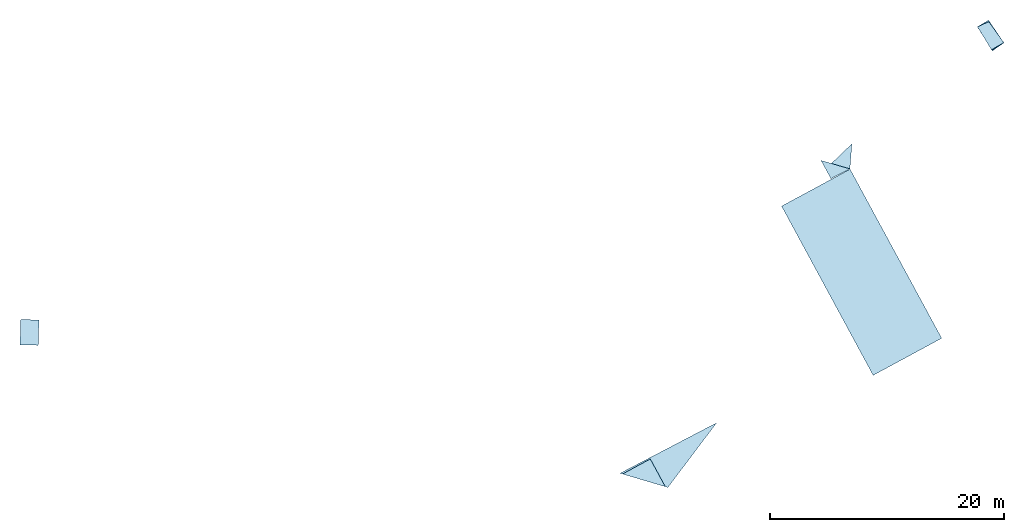
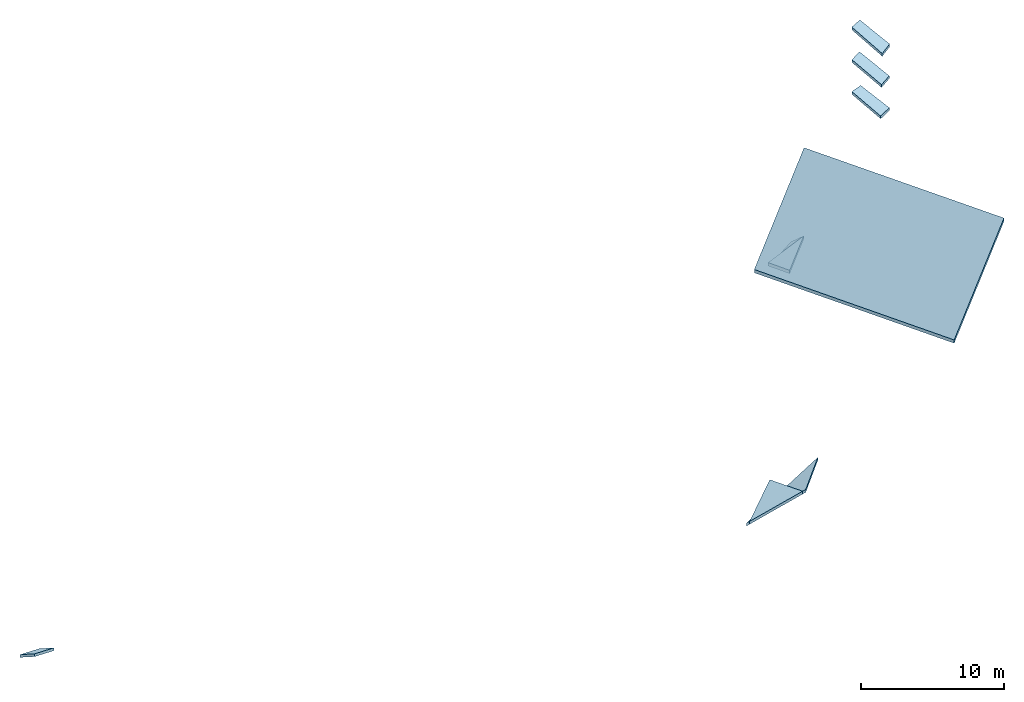
# One storey: 9 slabs, 1 element without a shape of its own.
"""IFC2X3 building model written with IfcOpenShell, lengths in metres."""

from ifc_helpers import new_model, entity, si_unit, converted_unit, derived_unit, direction, frame, origin, place, context, subcontext, project, spatial, polyline, outline, extrude, material, layer, layer_set, type_object, element, aggregate, save


model = new_model("IFC2X3")

# Units and contexts
model_context = context("Model", 3, precision=1e-05, world=origin(), true_north=direction((0.0, 1.0)))
body_context = subcontext(model_context, "Body", "Model", "MODEL_VIEW")
ifc_project = project(units=[si_unit("LENGTHUNIT", "METRE"), si_unit("AREAUNIT", "SQUARE_METRE"), si_unit("VOLUMEUNIT", "CUBIC_METRE"), converted_unit("PLANEANGLEUNIT", "DEGREE", entity("IfcRatioMeasure", 0.0174532925199433), si_unit("PLANEANGLEUNIT", "RADIAN"), dimensions=[0, 0, 0, 0, 0, 0, 0]), si_unit("MASSUNIT", "GRAM", prefix="KILO"), derived_unit("MASSDENSITYUNIT", [(si_unit("MASSUNIT", "GRAM", prefix="KILO"), 1), (si_unit("LENGTHUNIT", "METRE"), -3)]), derived_unit("MOMENTOFINERTIAUNIT", [(si_unit("LENGTHUNIT", "METRE"), 4)]), si_unit("TIMEUNIT", "SECOND"), si_unit("FREQUENCYUNIT", "HERTZ"), si_unit("THERMODYNAMICTEMPERATUREUNIT", "DEGREE_CELSIUS"), derived_unit("THERMALTRANSMITTANCEUNIT", [(si_unit("MASSUNIT", "GRAM", prefix="KILO"), 1), (si_unit("THERMODYNAMICTEMPERATUREUNIT", "KELVIN"), -1), (si_unit("TIMEUNIT", "SECOND"), -3)]), derived_unit("VOLUMETRICFLOWRATEUNIT", [(si_unit("LENGTHUNIT", "METRE"), 3), (si_unit("TIMEUNIT", "SECOND"), -1)]), si_unit("ELECTRICCURRENTUNIT", "AMPERE"), si_unit("ELECTRICVOLTAGEUNIT", "VOLT"), si_unit("POWERUNIT", "WATT"), si_unit("FORCEUNIT", "NEWTON", prefix="KILO"), si_unit("ILLUMINANCEUNIT", "LUX"), si_unit("LUMINOUSFLUXUNIT", "LUMEN"), si_unit("LUMINOUSINTENSITYUNIT", "CANDELA"), derived_unit("USERDEFINED", [(si_unit("MASSUNIT", "GRAM", prefix="KILO"), -1), (si_unit("LENGTHUNIT", "METRE"), -2), (si_unit("TIMEUNIT", "SECOND"), 3), (si_unit("LUMINOUSFLUXUNIT", "LUMEN"), 1)]), derived_unit("LINEARVELOCITYUNIT", [(si_unit("LENGTHUNIT", "METRE"), 1), (si_unit("TIMEUNIT", "SECOND"), -1)]), si_unit("PRESSUREUNIT", "PASCAL"), derived_unit("USERDEFINED", [(si_unit("LENGTHUNIT", "METRE"), -2), (si_unit("MASSUNIT", "GRAM", prefix="KILO"), 1), (si_unit("TIMEUNIT", "SECOND"), -2)]), derived_unit("LINEARFORCEUNIT", [(si_unit("MASSUNIT", "GRAM", prefix="KILO"), 1), (si_unit("LENGTHUNIT", "METRE"), 1), (si_unit("TIMEUNIT", "SECOND"), -2), (si_unit("LENGTHUNIT", "METRE"), -1)]), derived_unit("PLANARFORCEUNIT", [(si_unit("MASSUNIT", "GRAM", prefix="KILO"), 1), (si_unit("LENGTHUNIT", "METRE"), 1), (si_unit("TIMEUNIT", "SECOND"), -2), (si_unit("LENGTHUNIT", "METRE"), -2)])], contexts=[model_context])

# Site, building, storey
placement_1 = place(None, origin())
site = spatial("IfcSite", under=ifc_project, at=placement_1, CompositionType="ELEMENT")
building = spatial("IfcBuilding", under=site, at=placement_1, CompositionType="ELEMENT")
storey_placement = place(placement_1, frame((0.0, 0.0, 31.821325302124)))
storey = spatial("IfcBuildingStorey", under=building, at=storey_placement, Name="Level", CompositionType="ELEMENT", Elevation=31.821325302124)

# Roof, slabs
placement_2 = place(storey_placement, frame((-6.07346868515015, -33.4250411987305, 0.0)))
roof = element("IfcRoof", 1, at=placement_2, inside=storey, Name="Roof", ObjectType="Roof", ShapeType="NOTDEFINED")
ifc_material = material(Name="Roof default")
ifc_layer_1 = layer(ifc_material, 0.231103475607515)
ifc_layer_set_1 = layer_set([ifc_layer_1], Name="Roof : 231mm")
slab_type_1 = type_object("IfcSlabType", Name="Roof : 231mm", PredefinedType="ROOF")
slab_1 = element("IfcSlab", 2, at=placement_2, type_object=slab_type_1, material=ifc_layer_set_1, Name="Roof : 231mm", ObjectType="Roof : 231mm", PredefinedType="ROOF", context=body_context, shape_type="SweptSolid", body=[
    extrude(outline(polyline([(-1.37945548640333, -0.570175826322992), (1.28084587008976, -0.570175826322992), (1.32249920218578, 0.650591080261554), (-1.22388958587222, 0.48976057238443), (-1.37945548640333, -0.570175826322992)])), frame((82.951949596405, 24.317388176918, 3.69791507720947), z_axis=(0.269387876685073, -0.422480949692352, 0.865413207111006), x_axis=(0.45254965347922, -0.737696085330499, -0.501002292234172)), (0.501002292234172, 0.00753277468122775, -0.865413207111006), 0.231103475607515),
])
ifc_layer_2 = layer(ifc_material, 0.246837570702711)
ifc_layer_set_2 = layer_set([ifc_layer_2], Name="Roof : 247mm")
slab_type_2 = type_object("IfcSlabType", Name="Roof : 247mm", PredefinedType="ROOF")
slab_2 = element("IfcSlab", 3, at=placement_2, type_object=slab_type_2, material=ifc_layer_set_2, Name="Roof : 247mm", ObjectType="Roof : 247mm", PredefinedType="ROOF", context=body_context, shape_type="SweptSolid", body=[
    extrude(outline(polyline([(-2.29321118966516, -0.699426958294514), (1.99663056598749, -0.699426958294514), (0.296580623677674, 1.39885391658903), (-2.29321118966516, -0.699426958294514)])), frame((53.4909822146098, -13.15478515625, 2.7156810760498), z_axis=(-0.515052841201762, -0.279672019133781, 0.810249426092748), x_axis=(0.853648696351152, -0.252810824825446, 0.455379610950091)), (-0.455379610950091, -0.368952588152536, -0.810249426092748), 0.246837570702711),
])
ifc_layer_3 = layer(ifc_material, 0.286736122867555)
ifc_layer_set_3 = layer_set([ifc_layer_3], Name="Roof : 287mm")
slab_type_3 = type_object("IfcSlabType", Name="Roof : 287mm", PredefinedType="ROOF")
slab_3 = element("IfcSlab", 4, at=placement_2, type_object=slab_type_3, material=ifc_layer_set_3, Name="Roof : 287mm", ObjectType="Roof : 287mm", PredefinedType="ROOF", context=body_context, shape_type="SweptSolid", body=[
    extrude(outline(polyline([(-1.75380436932726, 0.59299205535376), (0.8696520481115, 0.59299205535376), (0.884152321215753, -1.18598411070752), (-1.75380436932726, 0.59299205535376)])), frame((69.5678445498149, 12.8426265716553, 1.97781562805176), z_axis=(-0.6271914955374, -0.346579018509989, 0.697505420662959), x_axis=(-0.619760830229879, -0.320317024407178, -0.716445055246878)), (0.716445055246878, 0.0138959866679809, -0.697505420662959), 0.286736122867555),
])
ifc_layer_4 = layer(ifc_material, 0.231432763462811)
ifc_layer_set_4 = layer_set([ifc_layer_4], Name="Roof : 231mm")
slab_type_4 = type_object("IfcSlabType", Name="Roof : 231mm", PredefinedType="ROOF")
slab_4 = element("IfcSlab", 5, at=placement_2, type_object=slab_type_4, material=ifc_layer_set_4, Name="Roof : 231mm", ObjectType="Roof : 231mm", PredefinedType="ROOF", context=body_context, shape_type="SweptSolid", body=[
    extrude(outline(polyline([(-1.35076795751455, -0.579947465231267), (1.36930573833615, -0.579947465231267), (1.34047400766751, 0.619872903054224), (-1.35901178848911, 0.540022027408309), (-1.35076795751455, -0.579947465231267)])), frame((82.955897808075, 24.3349380493164, 6.44432258605957), z_axis=(0.270101886591455, -0.424540520788289, 0.864181877308559), x_axis=(0.457661514382487, -0.733055210339754, -0.503165973458926)), (0.503165973458926, 0.00370373762776552, -0.864181877308559), 0.231432763462811),
])
ifc_layer_5 = layer(ifc_material, 0.288298507640401)
ifc_layer_set_5 = layer_set([ifc_layer_5], Name="Roof : 288mm")
slab_type_5 = type_object("IfcSlabType", Name="Roof : 288mm", PredefinedType="ROOF")
slab_5 = element("IfcSlab", 6, at=placement_2, type_object=slab_type_5, material=ifc_layer_set_5, Name="Roof : 288mm", ObjectType="Roof : 288mm", PredefinedType="ROOF", context=body_context, shape_type="SweptSolid", body=[
    extrude(outline(polyline([(-1.16671485055605, 0.821125258955483), (0.872767405213462, 0.821125258955483), (0.293947445342562, -1.64225051791098), (-1.16671485055605, 0.821125258955483)])), frame((70.4632493654887, 13.751963297526, 2.19853782653809), z_axis=(-0.336858244307122, 0.636609441306794, 0.693725408559737), x_axis=(-0.777587772758233, 0.227366913146861, -0.586226528283187)), (0.586226528283187, -0.418429298406493, -0.693725408559737), 0.288298507640401),
])
ifc_layer_6 = layer(ifc_material, 0.246747940729029)
ifc_layer_set_6 = layer_set([ifc_layer_6], Name="Roof : 247mm")
slab_type_6 = type_object("IfcSlabType", Name="Roof : 247mm", PredefinedType="ROOF")
slab_6 = element("IfcSlab", 7, at=placement_2, type_object=slab_type_6, material=ifc_layer_set_6, Name="Roof : 247mm", ObjectType="Roof : 247mm", PredefinedType="ROOF", context=body_context, shape_type="SweptSolid", body=[
    extrude(outline(polyline([(-1.1946570100708, 2.37594798964786), (3.60838682693033, 2.37594798964786), (-2.41372981685953, -4.7518959792957), (-1.1946570100708, 2.37594798964786)])), frame((55.3854384422302, -12.1237233479818, 2.06545702616373), z_axis=(-0.280048398884649, 0.514384808671526, 0.810543745204478), x_axis=(-0.853649658191817, 0.252809744784515, -0.455378407493133)), (0.455378407493133, -0.368305451852236, -0.810543745204478), 0.246747940729029),
])
ifc_layer_7 = layer(ifc_material, 0.231856108437814)
ifc_layer_set_7 = layer_set([ifc_layer_7], Name="Roof : 232mm")
slab_type_7 = type_object("IfcSlabType", Name="Roof : 232mm", PredefinedType="ROOF")
slab_7 = element("IfcSlab", 8, at=placement_2, type_object=slab_type_7, material=ifc_layer_set_7, Name="Roof : 232mm", ObjectType="Roof : 232mm", PredefinedType="ROOF", context=body_context, shape_type="SweptSolid", body=[
    extrude(outline(polyline([(-1.41139660368443, -0.575377520918237), (1.42772736686194, -0.575377520918237), (1.33095455482333, 0.645075454335495), (-1.34728531800084, 0.505679587500979), (-1.41139660368443, -0.575377520918237)])), frame((82.9750437736511, 24.3189911842346, 9.17491817474365), z_axis=(0.266145518811733, -0.430210356493155, 0.862603971694118), x_axis=(0.441265555919492, -0.741232577843161, -0.505825043570446)), (0.505825043570446, 0.00743871686995082, -0.862603971694118), 0.231856108437814),
])
ifc_layer_8 = layer(ifc_material, 0.278567151745947)
ifc_layer_set_8 = layer_set([ifc_layer_8], Name="Roof : 279mm")
slab_type_8 = type_object("IfcSlabType", Name="Roof : 279mm", PredefinedType="ROOF")
slab_8 = element("IfcSlab", 9, at=placement_2, type_object=slab_type_8, material=ifc_layer_set_8, Name="Roof : 279mm", ObjectType="Roof : 279mm", PredefinedType="ROOF", context=body_context, shape_type="SweptSolid", body=[
    extrude(outline(polyline([(-4.64602507617343, 8.22999735448281), (4.6339710278607, 8.22999735448281), (4.65004152765695, -8.22999785611967), (-4.63798747934422, -8.22999685284594), (-4.64602507617343, 8.22999735448281)])), frame((71.934916973114, 4.03990697860718, 7.55216026306152), z_axis=(-0.612147968945109, -0.331373920263916, 0.717959740574151), x_axis=(0.631617942791141, 0.341358204804834, 0.696084298312142)), (-0.696084298312142, -0.000339982057702907, -0.717959740574151), 0.278567151745947),
])
ifc_layer_9 = layer(ifc_material, 0.238365505356285)
ifc_layer_set_9 = layer_set([ifc_layer_9], Name="Roof : 238mm")
slab_type_9 = type_object("IfcSlabType", Name="Roof : 238mm", PredefinedType="ROOF")
slab_9 = element("IfcSlab", 10, at=placement_2, type_object=slab_type_9, material=ifc_layer_set_9, Name="Roof : 238mm", ObjectType="Roof : 238mm", PredefinedType="ROOF", context=body_context, shape_type="SweptSolid", body=[
    extrude(outline(polyline([(-0.780001536341328, 1.28999965376606), (0.779998371209794, 1.28999965376606), (0.780001536341328, -1.28999965376606), (-0.779998371209794, -1.28999965376606), (-0.780001536341328, 1.28999965376606)])), frame((0.7465500831604, -1.10570907592773, 0.701834678649902), z_axis=(0.0166312803583344, 0.543803789982613, 0.839047578218416), x_axis=(0.999532661006616, -0.0305689316305395, 0.0)), (0.0, 0.544058049739006, -0.839047578218416), 0.238365505356285),
])
aggregate(roof, [slab_1, slab_2, slab_3, slab_4, slab_5, slab_6, slab_7, slab_8, slab_9])

save(model, "model.ifc")
